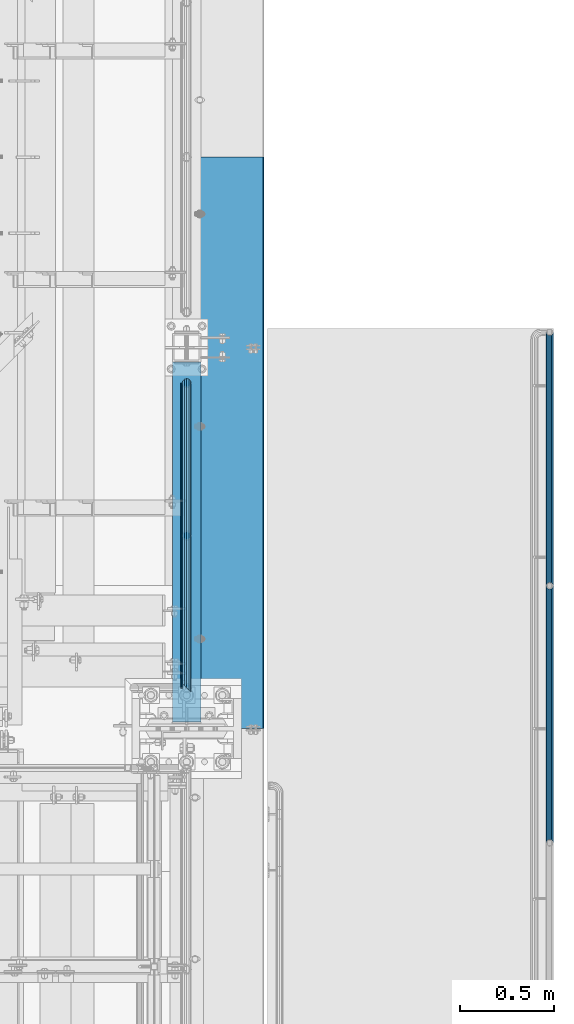
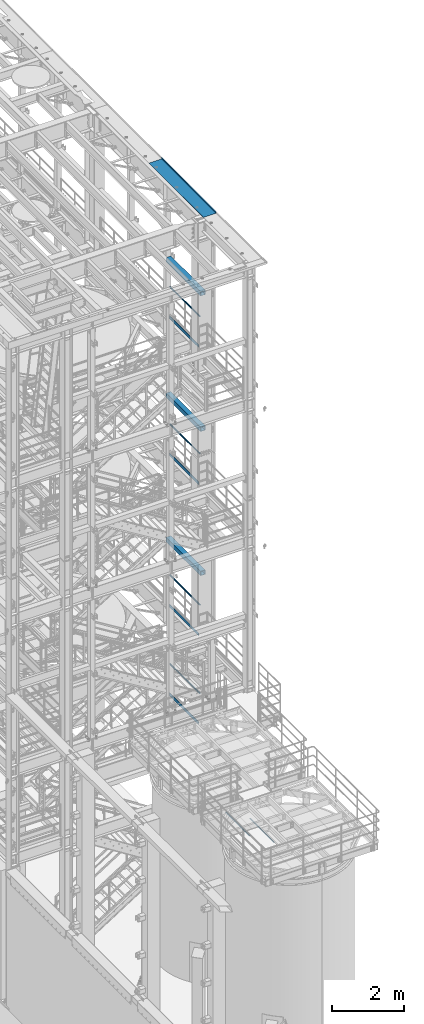
# One storey, part 1005 of 1876: 14 beams, 9 elements without a shape of their own.
"""IFC2X3 building model written with IfcOpenShell, lengths in millimetres."""

from ifc_helpers import new_model, si_unit, frame, origin_with_axes, place, context, subcontext, project, spatial, faceted_brep, material, type_object, element, aggregate, save


model = new_model("IFC2X3")

# Units and contexts
model_context = context("Model", 3, precision=1e-05, world=origin_with_axes())
body_context = subcontext(model_context, "Body", "Model", "MODEL_VIEW")
ifc_project = project(units=[si_unit("LENGTHUNIT", "METRE", prefix="MILLI"), si_unit("AREAUNIT", "SQUARE_METRE"), si_unit("VOLUMEUNIT", "CUBIC_METRE"), si_unit("MASSUNIT", "GRAM", prefix="KILO"), si_unit("TIMEUNIT", "SECOND"), si_unit("PLANEANGLEUNIT", "RADIAN"), si_unit("SOLIDANGLEUNIT", "STERADIAN"), si_unit("THERMODYNAMICTEMPERATUREUNIT", "DEGREE_CELSIUS"), si_unit("LUMINOUSINTENSITYUNIT", "LUMEN")], contexts=[model_context])

# Site, building, storey
site_placement = place(None, origin_with_axes())
site = spatial("IfcSite", under=ifc_project, at=site_placement, CompositionType="ELEMENT")
building_placement = place(site_placement, origin_with_axes())
building = spatial("IfcBuilding", under=site, at=building_placement, Name="Undefined", CompositionType="ELEMENT")
storey_placement = place(building_placement, origin_with_axes())
storey = spatial("IfcBuildingStorey", under=building, at=storey_placement, Name="Undefined", CompositionType="ELEMENT", Elevation=0.0)

# Assembly, beam
assembly_1_placement = place(storey_placement, origin_with_axes())
assembly_1 = element("IfcElementAssembly", 1, at=assembly_1_placement, inside=storey, Name="RAIL", AssemblyPlace="NOTDEFINED", PredefinedType="RIGID_FRAME")
ifc_material_1 = material()
beam_type_1 = type_object("IfcBeamType", Name="PIPE1-1/2SCH40", PredefinedType="NOTDEFINED")
beam_1_placement = place(assembly_1_placement, frame((7620.0, -4380.23, 19059.525), z_axis=(0.0, 0.0, -1.0), x_axis=(0.0, 1.0, 0.0)))
beam_1 = element("IfcBeam", 2, at=beam_1_placement, type_object=beam_type_1, material=ifc_material_1, Name="RAIL", ObjectType="PIPE1-1/2SCH40", context=body_context, shape_type="Brep", body=[
    faceted_brep([(44.5769999999984, -20.4470000000001, 0.0), (41.8376214311784, -17.7076214311801, 10.2235000000001), (1640.7003, -17.7076214311801, 10.2235000000001), (1650.9238, -20.4470000000001, 0.0), (34.3534999999983, -10.2235000000001, 17.7076214311819), (1633.21617856882, -10.2235000000001, 17.7076214311819), (24.1300000000064, 0.0, 20.4470000000001), (1630.4768, 0.0, 20.4470000000001), (13.9064999999982, 10.2235000000001, 17.7076214311819), (1633.21617856882, 10.2235000000001, 17.7076214311819), (6.4223785688182, 17.7076214311801, 10.2235000000001), (1640.7003, 17.7076214311801, 10.2235000000001), (3.68299999999817, 20.4470000000001, 0.0), (1650.9238, 20.4470000000001, 0.0), (6.4223785688182, 17.7076214311801, -10.2235000000001), (1661.1473, 17.7076214311801, -10.2235000000001), (13.9064999999982, 10.2235000000001, -17.7076214311819), (1668.63142143118, 10.2235000000001, -17.7076214311819), (24.1300000000063, 0.0, -20.4470000000001), (1671.3708, 0.0, -20.4470000000001), (34.3534999999983, -10.2235000000001, -17.7076214311819), (1668.63142143118, -10.2235000000001, -17.7076214311819), (41.8376214311784, -17.7076214311801, -10.2235000000001), (1661.1473, -17.7076214311801, -10.2235000000001), (48.2599999999984, -24.1300000000001, 0.0), (45.0271929933169, -20.8971929933186, -12.0649999999987), (1662.9888, -20.8971929933186, -12.0649999999987), (1650.9238, -24.1300000000001, 0.0), (36.1949999999979, -12.0649999999996, -20.8971929933177), (1671.82099299332, -12.0649999999996, -20.8971929933177), (24.1300000000063, 0.0, -24.130000000001), (1675.0538, 0.0, -24.130000000001), (12.0650000000041, 12.0650000000005, -20.8971929933177), (1671.82099299332, 12.0649999999996, -20.8971929933177), (3.23280700667965, 20.8971929933186, -12.0649999999987), (1662.9888, 20.8971929933186, -12.0649999999987), (0.0, 24.1299999999992, 0.0), (1650.9238, 24.1300000000001, 0.0), (3.23280700667965, 20.8971929933186, 12.0649999999987), (1638.8588, 20.8971929933186, 12.0649999999987), (12.0650000000041, 12.0650000000005, 20.8971929933177), (1630.02660700668, 12.0649999999996, 20.8971929933177), (24.1300000000064, 0.0, 24.130000000001), (1626.7938, 0.0, 24.130000000001), (36.1949999999979, -12.0649999999996, 20.8971929933177), (1630.02660700668, -12.0649999999996, 20.8971929933177), (45.0271929933169, -20.8971929933186, 12.0649999999987), (1638.8588, -20.8971929933186, 12.0649999999987)], [[[0, 1, 2, 3]], [[1, 4, 5, 2]], [[4, 6, 7, 5]], [[6, 8, 9, 7]], [[8, 10, 11, 9]], [[10, 12, 13, 11]], [[12, 14, 15, 13]], [[14, 16, 17, 15]], [[16, 18, 19, 17]], [[18, 20, 21, 19]], [[20, 22, 23, 21]], [[22, 0, 3, 23]], [[24, 25, 26, 27]], [[25, 28, 29, 26]], [[28, 30, 31, 29]], [[30, 32, 33, 31]], [[32, 34, 35, 33]], [[34, 36, 37, 35]], [[36, 38, 39, 37]], [[38, 40, 41, 39]], [[40, 42, 43, 41]], [[42, 44, 45, 43]], [[44, 46, 47, 45]], [[46, 24, 27, 47]], [[29, 31, 33, 35, 37, 39, 41, 43, 45, 47, 27, 26], [5, 7, 9, 11, 13, 15, 17, 19, 21, 23, 3, 2]], [[46, 44, 42, 40, 38, 36, 34, 32, 30, 28, 25, 24], [22, 20, 18, 16, 14, 12, 10, 8, 6, 4, 1, 0]]]),
])

assembly_2_placement = place(storey_placement, origin_with_axes())
assembly_2 = element("IfcElementAssembly", 3, at=assembly_2_placement, inside=storey, Name="RAIL", AssemblyPlace="NOTDEFINED", PredefinedType="RIGID_FRAME")
beam_2_placement = place(assembly_2_placement, frame((7620.0, -4380.23, 14385.925), z_axis=(0.0, 0.0, -1.0), x_axis=(0.0, 1.0, 0.0)))
beam_2 = element("IfcBeam", 4, at=beam_2_placement, type_object=beam_type_1, material=ifc_material_1, Name="RAIL", ObjectType="PIPE1-1/2SCH40", context=body_context, shape_type="Brep", body=[
    faceted_brep([(44.5769999999984, -20.4470000000001, 0.0), (41.8376214311784, -17.7076214311801, 10.2235000000001), (1640.7003, -17.7076214311801, 10.2235000000001), (1650.9238, -20.4470000000001, 0.0), (34.3534999999983, -10.2235000000001, 17.7076214311819), (1633.21617856882, -10.2235000000001, 17.7076214311819), (24.1300000000064, 0.0, 20.4470000000001), (1630.4768, 0.0, 20.4470000000001), (13.9064999999982, 10.2235000000001, 17.7076214311819), (1633.21617856882, 10.2235000000001, 17.7076214311819), (6.4223785688182, 17.7076214311801, 10.2235000000001), (1640.7003, 17.7076214311801, 10.2235000000001), (3.68299999999817, 20.4470000000001, 0.0), (1650.9238, 20.4470000000001, 0.0), (6.4223785688182, 17.7076214311801, -10.2235000000001), (1661.1473, 17.7076214311801, -10.2235000000001), (13.9064999999982, 10.2235000000001, -17.7076214311819), (1668.63142143118, 10.2235000000001, -17.7076214311819), (24.1300000000063, 0.0, -20.4470000000001), (1671.3708, 0.0, -20.4470000000001), (34.3534999999983, -10.2235000000001, -17.7076214311819), (1668.63142143118, -10.2235000000001, -17.7076214311819), (41.8376214311784, -17.7076214311801, -10.2235000000001), (1661.1473, -17.7076214311801, -10.2235000000001), (48.2599999999984, -24.1300000000001, 0.0), (45.0271929933169, -20.8971929933186, -12.0649999999987), (1662.9888, -20.8971929933186, -12.0649999999987), (1650.9238, -24.1300000000001, 0.0), (36.1949999999979, -12.0649999999996, -20.8971929933177), (1671.82099299332, -12.0649999999996, -20.8971929933177), (24.1300000000063, 0.0, -24.130000000001), (1675.0538, 0.0, -24.130000000001), (12.0650000000041, 12.0650000000005, -20.8971929933177), (1671.82099299332, 12.0649999999996, -20.8971929933177), (3.23280700667965, 20.8971929933186, -12.0649999999987), (1662.9888, 20.8971929933186, -12.0649999999987), (0.0, 24.1299999999992, 0.0), (1650.9238, 24.1300000000001, 0.0), (3.23280700667965, 20.8971929933186, 12.0649999999987), (1638.8588, 20.8971929933186, 12.0649999999987), (12.0650000000041, 12.0650000000005, 20.8971929933177), (1630.02660700668, 12.0649999999996, 20.8971929933177), (24.1300000000064, 0.0, 24.130000000001), (1626.7938, 0.0, 24.130000000001), (36.1949999999979, -12.0649999999996, 20.8971929933177), (1630.02660700668, -12.0649999999996, 20.8971929933177), (45.0271929933169, -20.8971929933186, 12.0649999999987), (1638.8588, -20.8971929933186, 12.0649999999987)], [[[0, 1, 2, 3]], [[1, 4, 5, 2]], [[4, 6, 7, 5]], [[6, 8, 9, 7]], [[8, 10, 11, 9]], [[10, 12, 13, 11]], [[12, 14, 15, 13]], [[14, 16, 17, 15]], [[16, 18, 19, 17]], [[18, 20, 21, 19]], [[20, 22, 23, 21]], [[22, 0, 3, 23]], [[24, 25, 26, 27]], [[25, 28, 29, 26]], [[28, 30, 31, 29]], [[30, 32, 33, 31]], [[32, 34, 35, 33]], [[34, 36, 37, 35]], [[36, 38, 39, 37]], [[38, 40, 41, 39]], [[40, 42, 43, 41]], [[42, 44, 45, 43]], [[44, 46, 47, 45]], [[46, 24, 27, 47]], [[29, 31, 33, 35, 37, 39, 41, 43, 45, 47, 27, 26], [5, 7, 9, 11, 13, 15, 17, 19, 21, 23, 3, 2]], [[46, 44, 42, 40, 38, 36, 34, 32, 30, 28, 25, 24], [22, 20, 18, 16, 14, 12, 10, 8, 6, 4, 1, 0]]]),
])

assembly_3_placement = place(storey_placement, origin_with_axes())
assembly_3 = element("IfcElementAssembly", 5, at=assembly_3_placement, inside=storey, Name="RAIL", AssemblyPlace="NOTDEFINED", PredefinedType="RIGID_FRAME")
beam_3_placement = place(assembly_3_placement, frame((7620.0, -4380.23, 9229.725), z_axis=(0.0, 0.0, -1.0), x_axis=(0.0, 1.0, 0.0)))
beam_3 = element("IfcBeam", 6, at=beam_3_placement, type_object=beam_type_1, material=ifc_material_1, Name="RAIL", ObjectType="PIPE1-1/2SCH40", context=body_context, shape_type="Brep", body=[
    faceted_brep([(44.5769999999984, -20.4470000000001, 0.0), (41.8376214311784, -17.7076214311801, 10.2235000000001), (1640.7003, -17.7076214311801, 10.2235000000001), (1650.9238, -20.4470000000001, 0.0), (34.3534999999983, -10.2235000000001, 17.7076214311819), (1633.21617856882, -10.2235000000001, 17.7076214311819), (24.1300000000064, 0.0, 20.4470000000001), (1630.4768, 0.0, 20.4470000000001), (13.9064999999982, 10.2235000000001, 17.7076214311819), (1633.21617856882, 10.2235000000001, 17.7076214311819), (6.4223785688182, 17.7076214311801, 10.2235000000001), (1640.7003, 17.7076214311801, 10.2235000000001), (3.68299999999817, 20.4470000000001, 0.0), (1650.9238, 20.4470000000001, 0.0), (6.4223785688182, 17.7076214311801, -10.2235000000001), (1661.1473, 17.7076214311801, -10.2235000000001), (13.9064999999982, 10.2235000000001, -17.7076214311819), (1668.63142143118, 10.2235000000001, -17.7076214311819), (24.1300000000063, 0.0, -20.4470000000001), (1671.3708, 0.0, -20.4470000000001), (34.3534999999983, -10.2235000000001, -17.7076214311819), (1668.63142143118, -10.2235000000001, -17.7076214311819), (41.8376214311784, -17.7076214311801, -10.2235000000001), (1661.1473, -17.7076214311801, -10.2235000000001), (48.2599999999984, -24.1300000000001, 0.0), (45.0271929933169, -20.8971929933186, -12.0649999999987), (1662.9888, -20.8971929933186, -12.0649999999987), (1650.9238, -24.1300000000001, 0.0), (36.1949999999979, -12.0649999999996, -20.8971929933177), (1671.82099299332, -12.0649999999996, -20.8971929933177), (24.1300000000063, 0.0, -24.130000000001), (1675.0538, 0.0, -24.130000000001), (12.0650000000041, 12.0650000000005, -20.8971929933177), (1671.82099299332, 12.0649999999996, -20.8971929933177), (3.23280700667965, 20.8971929933186, -12.0649999999987), (1662.9888, 20.8971929933186, -12.0649999999987), (0.0, 24.1299999999992, 0.0), (1650.9238, 24.1300000000001, 0.0), (3.23280700667965, 20.8971929933186, 12.0649999999987), (1638.8588, 20.8971929933186, 12.0649999999987), (12.0650000000041, 12.0650000000005, 20.8971929933177), (1630.02660700668, 12.0649999999996, 20.8971929933177), (24.1300000000064, 0.0, 24.130000000001), (1626.7938, 0.0, 24.130000000001), (36.1949999999979, -12.0649999999996, 20.8971929933177), (1630.02660700668, -12.0649999999996, 20.8971929933177), (45.0271929933169, -20.8971929933186, 12.0649999999987), (1638.8588, -20.8971929933186, 12.0649999999987)], [[[0, 1, 2, 3]], [[1, 4, 5, 2]], [[4, 6, 7, 5]], [[6, 8, 9, 7]], [[8, 10, 11, 9]], [[10, 12, 13, 11]], [[12, 14, 15, 13]], [[14, 16, 17, 15]], [[16, 18, 19, 17]], [[18, 20, 21, 19]], [[20, 22, 23, 21]], [[22, 0, 3, 23]], [[24, 25, 26, 27]], [[25, 28, 29, 26]], [[28, 30, 31, 29]], [[30, 32, 33, 31]], [[32, 34, 35, 33]], [[34, 36, 37, 35]], [[36, 38, 39, 37]], [[38, 40, 41, 39]], [[40, 42, 43, 41]], [[42, 44, 45, 43]], [[44, 46, 47, 45]], [[46, 24, 27, 47]], [[29, 31, 33, 35, 37, 39, 41, 43, 45, 47, 27, 26], [5, 7, 9, 11, 13, 15, 17, 19, 21, 23, 3, 2]], [[46, 44, 42, 40, 38, 36, 34, 32, 30, 28, 25, 24], [22, 20, 18, 16, 14, 12, 10, 8, 6, 4, 1, 0]]]),
])

assembly_4_placement = place(storey_placement, origin_with_axes())
assembly_4 = element("IfcElementAssembly", 7, at=assembly_4_placement, inside=storey, Name="RAIL", AssemblyPlace="NOTDEFINED", PredefinedType="RIGID_FRAME")
beam_4_placement = place(assembly_4_placement, frame((7620.0, -4380.23, 6207.125), z_axis=(0.0, 0.0, -1.0), x_axis=(0.0, 1.0, 0.0)))
beam_4 = element("IfcBeam", 8, at=beam_4_placement, type_object=beam_type_1, material=ifc_material_1, Name="RAIL", ObjectType="PIPE1-1/2SCH40", context=body_context, shape_type="Brep", body=[
    faceted_brep([(44.5769999999984, -20.4470000000001, 0.0), (41.8376214311784, -17.7076214311801, 10.2235000000001), (1640.7003, -17.7076214311801, 10.2235000000001), (1650.9238, -20.4470000000001, 0.0), (34.3534999999983, -10.2235000000001, 17.7076214311819), (1633.21617856882, -10.2235000000001, 17.7076214311819), (24.1300000000064, 0.0, 20.4470000000001), (1630.4768, 0.0, 20.4470000000001), (13.9064999999982, 10.2235000000001, 17.7076214311819), (1633.21617856882, 10.2235000000001, 17.7076214311819), (6.4223785688182, 17.7076214311801, 10.2235000000001), (1640.7003, 17.7076214311801, 10.2235000000001), (3.68299999999817, 20.4470000000001, 0.0), (1650.9238, 20.4470000000001, 0.0), (6.4223785688182, 17.7076214311801, -10.2235000000001), (1661.1473, 17.7076214311801, -10.2235000000001), (13.9064999999982, 10.2235000000001, -17.7076214311819), (1668.63142143118, 10.2235000000001, -17.7076214311819), (24.1300000000063, 0.0, -20.4470000000001), (1671.3708, 0.0, -20.4470000000001), (34.3534999999983, -10.2235000000001, -17.7076214311819), (1668.63142143118, -10.2235000000001, -17.7076214311819), (41.8376214311784, -17.7076214311801, -10.2235000000001), (1661.1473, -17.7076214311801, -10.2235000000001), (48.2599999999984, -24.1300000000001, 0.0), (45.0271929933169, -20.8971929933186, -12.0649999999987), (1662.9888, -20.8971929933186, -12.0649999999987), (1650.9238, -24.1300000000001, 0.0), (36.1949999999979, -12.0649999999996, -20.8971929933177), (1671.82099299332, -12.0649999999996, -20.8971929933177), (24.1300000000063, 0.0, -24.130000000001), (1675.0538, 0.0, -24.130000000001), (12.0650000000041, 12.0650000000005, -20.8971929933177), (1671.82099299332, 12.0649999999996, -20.8971929933177), (3.23280700667965, 20.8971929933186, -12.0649999999987), (1662.9888, 20.8971929933186, -12.0649999999987), (0.0, 24.1299999999992, 0.0), (1650.9238, 24.1300000000001, 0.0), (3.23280700667965, 20.8971929933186, 12.0649999999987), (1638.8588, 20.8971929933186, 12.0649999999987), (12.0650000000041, 12.0650000000005, 20.8971929933177), (1630.02660700668, 12.0649999999996, 20.8971929933177), (24.1300000000064, 0.0, 24.130000000001), (1626.7938, 0.0, 24.130000000001), (36.1949999999979, -12.0649999999996, 20.8971929933177), (1630.02660700668, -12.0649999999996, 20.8971929933177), (45.0271929933169, -20.8971929933186, 12.0649999999987), (1638.8588, -20.8971929933186, 12.0649999999987)], [[[0, 1, 2, 3]], [[1, 4, 5, 2]], [[4, 6, 7, 5]], [[6, 8, 9, 7]], [[8, 10, 11, 9]], [[10, 12, 13, 11]], [[12, 14, 15, 13]], [[14, 16, 17, 15]], [[16, 18, 19, 17]], [[18, 20, 21, 19]], [[20, 22, 23, 21]], [[22, 0, 3, 23]], [[24, 25, 26, 27]], [[25, 28, 29, 26]], [[28, 30, 31, 29]], [[30, 32, 33, 31]], [[32, 34, 35, 33]], [[34, 36, 37, 35]], [[36, 38, 39, 37]], [[38, 40, 41, 39]], [[40, 42, 43, 41]], [[42, 44, 45, 43]], [[44, 46, 47, 45]], [[46, 24, 27, 47]], [[29, 31, 33, 35, 37, 39, 41, 43, 45, 47, 27, 26], [5, 7, 9, 11, 13, 15, 17, 19, 21, 23, 3, 2]], [[46, 44, 42, 40, 38, 36, 34, 32, 30, 28, 25, 24], [22, 20, 18, 16, 14, 12, 10, 8, 6, 4, 1, 0]]]),
])

assembly_5_placement = place(storey_placement, origin_with_axes())
assembly_5 = element("IfcElementAssembly", 9, at=assembly_5_placement, inside=storey, Name="BEAM", AssemblyPlace="NOTDEFINED", PredefinedType="RIGID_FRAME")
ifc_material_2 = material()
beam_type_2 = type_object("IfcBeamType", Name="HSS6X6X3/8", PredefinedType="NOTDEFINED")
beam_5_placement = place(assembly_5_placement, frame((7620.0, -4560.09375, 19958.05), z_axis=(-1.0, 0.0, 0.0), x_axis=(0.0, 1.0, 0.0)))
beam_5 = element("IfcBeam", 10, at=beam_5_placement, type_object=beam_type_2, material=ifc_material_2, Name="BEAM", ObjectType="HSS6X6X3/8", context=body_context, shape_type="Brep", body=[
    faceted_brep([(22.2249999999995, 66.6749999999993, -66.675), (22.2249999999995, -66.6749999999993, -66.675), (1943.89375, -66.6749999999993, -66.675), (1943.89375, 66.6749999999993, -66.675), (22.2249999999995, -66.6749999999993, 66.675), (1943.89375, -66.6749999999993, 66.675), (22.2249999999995, 66.6749999999993, 66.675), (1943.89375, 66.6749999999993, 66.675), (22.2249999999995, 76.2000000000007, -76.2), (22.2249999999995, 76.2000000000007, 76.2), (1943.89375, 76.2000000000007, 76.2), (1943.89375, 76.2000000000007, -76.2), (22.2249999999995, -76.2000000000007, 76.2), (1943.89375, -76.2000000000007, 76.2), (22.2249999999995, -76.2000000000007, -76.2), (1943.89375, -76.2000000000007, -76.2)], [[[0, 1, 2, 3]], [[1, 4, 5, 2]], [[4, 6, 7, 5]], [[6, 0, 3, 7]], [[8, 9, 10, 11]], [[9, 12, 13, 10]], [[12, 14, 15, 13]], [[14, 8, 11, 15]], [[13, 15, 11, 10], [5, 7, 3, 2]], [[14, 12, 9, 8], [6, 4, 1, 0]]]),
])
aggregate(assembly_5, [beam_5])

assembly_6_placement = place(storey_placement, origin_with_axes())
assembly_6 = element("IfcElementAssembly", 11, at=assembly_6_placement, inside=storey, Name="BEAM", AssemblyPlace="NOTDEFINED", PredefinedType="RIGID_FRAME")
beam_6_placement = place(assembly_6_placement, frame((7620.0, -4560.09375, 15335.25), z_axis=(-1.0, 0.0, 0.0), x_axis=(0.0, 1.0, 0.0)))
beam_6 = element("IfcBeam", 12, at=beam_6_placement, type_object=beam_type_2, material=ifc_material_2, Name="BEAM", ObjectType="HSS6X6X3/8", context=body_context, shape_type="Brep", body=[
    faceted_brep([(22.2249999999995, 66.6749999999993, -66.675), (22.2249999999995, -66.6749999999993, -66.675), (1943.89375, -66.6749999999993, -66.675), (1943.89375, 66.6749999999993, -66.675), (22.2249999999995, -66.6749999999993, 66.675), (1943.89375, -66.6749999999993, 66.675), (22.2249999999995, 66.6749999999993, 66.675), (1943.89375, 66.6749999999993, 66.675), (22.2249999999995, 76.2000000000007, -76.2), (22.2249999999995, 76.2000000000007, 76.2), (1943.89375, 76.2000000000007, 76.2), (1943.89375, 76.2000000000007, -76.2), (22.2249999999995, -76.2000000000007, 76.2), (1943.89375, -76.2000000000007, 76.2), (22.2249999999995, -76.2000000000007, -76.2), (1943.89375, -76.2000000000007, -76.2)], [[[0, 1, 2, 3]], [[1, 4, 5, 2]], [[4, 6, 7, 5]], [[6, 0, 3, 7]], [[8, 9, 10, 11]], [[9, 12, 13, 10]], [[12, 14, 15, 13]], [[14, 8, 11, 15]], [[13, 15, 11, 10], [5, 7, 3, 2]], [[14, 12, 9, 8], [6, 4, 1, 0]]]),
])
aggregate(assembly_6, [beam_6])

assembly_7_placement = place(storey_placement, origin_with_axes())
assembly_7 = element("IfcElementAssembly", 13, at=assembly_7_placement, inside=storey, Name="BEAM", AssemblyPlace="NOTDEFINED", PredefinedType="RIGID_FRAME")
beam_7_placement = place(assembly_7_placement, frame((7620.0, -4560.09375, 10420.35), z_axis=(-1.0, 0.0, 0.0), x_axis=(0.0, 1.0, 0.0)))
beam_7 = element("IfcBeam", 14, at=beam_7_placement, type_object=beam_type_2, material=ifc_material_2, Name="BEAM", ObjectType="HSS6X6X3/8", context=body_context, shape_type="Brep", body=[
    faceted_brep([(22.2249999999995, 66.6749999999993, -66.675), (22.2249999999995, -66.6749999999993, -66.675), (1943.89375, -66.6749999999993, -66.675), (1943.89375, 66.6749999999993, -66.675), (22.2249999999995, -66.6749999999993, 66.675), (1943.89375, -66.6749999999993, 66.675), (22.2249999999995, 66.6749999999993, 66.675), (1943.89375, 66.6749999999993, 66.675), (22.2249999999995, 76.2000000000007, -76.2), (22.2249999999995, 76.2000000000007, 76.2), (1943.89375, 76.2000000000007, 76.2), (1943.89375, 76.2000000000007, -76.2), (22.2249999999995, -76.2000000000007, 76.2), (1943.89375, -76.2000000000007, 76.2), (22.2249999999995, -76.2000000000007, -76.2), (1943.89375, -76.2000000000007, -76.2)], [[[0, 1, 2, 3]], [[1, 4, 5, 2]], [[4, 6, 7, 5]], [[6, 0, 3, 7]], [[8, 9, 10, 11]], [[9, 12, 13, 10]], [[12, 14, 15, 13]], [[14, 8, 11, 15]], [[13, 15, 11, 10], [5, 7, 3, 2]], [[14, 12, 9, 8], [6, 4, 1, 0]]]),
])
aggregate(assembly_7, [beam_7])

# Beam
ifc_material_3 = material(Name="STEEL/A36")
beam_type_3 = type_object("IfcBeamType", PredefinedType="NOTDEFINED")
beam_8_placement = place(assembly_1_placement, frame((7592.69500000001, -4356.10000000001, 18049.875), z_axis=(0.0, 0.0, 1.0), x_axis=(0.0, 1.0, 0.0)))
beam_8 = element("IfcBeam", 15, at=beam_8_placement, type_object=beam_type_3, material=ifc_material_3, Name="PLATE", context=body_context, shape_type="Brep", body=[
    faceted_brep([(0.0, 3.17500000000018, -50.8000000000002), (0.0, 3.17500000000018, 50.8000000000002), (1626.7938, 3.175, 50.7999999999993), (1626.7938, 3.175, -50.7999999999993), (0.0, -3.17500000000018, 50.8000000000002), (1626.7938, -3.175, 50.7999999999993), (0.0, -3.17500000000018, -50.8000000000002), (1626.7938, -3.175, -50.7999999999993)], [[[0, 1, 2, 3]], [[1, 4, 5, 2]], [[4, 6, 7, 5]], [[6, 0, 3, 7]], [[5, 7, 3, 2]], [[6, 4, 1, 0]]]),
])

aggregate(assembly_1, [beam_8, beam_1])

beam_9_placement = place(assembly_2_placement, frame((7592.69500000001, -4356.10000000001, 13376.275), z_axis=(0.0, 0.0, 1.0), x_axis=(0.0, 1.0, 0.0)))
beam_9 = element("IfcBeam", 16, at=beam_9_placement, type_object=beam_type_3, material=ifc_material_3, Name="PLATE", context=body_context, shape_type="Brep", body=[
    faceted_brep([(0.0, 3.17500000000018, -50.8000000000002), (0.0, 3.17500000000018, 50.8000000000002), (1626.7938, 3.175, 50.7999999999993), (1626.7938, 3.175, -50.7999999999993), (0.0, -3.17500000000018, 50.8000000000002), (1626.7938, -3.175, 50.7999999999993), (0.0, -3.17500000000018, -50.8000000000002), (1626.7938, -3.175, -50.7999999999993)], [[[0, 1, 2, 3]], [[1, 4, 5, 2]], [[4, 6, 7, 5]], [[6, 0, 3, 7]], [[5, 7, 3, 2]], [[6, 4, 1, 0]]]),
])

aggregate(assembly_2, [beam_9, beam_2])

beam_10_placement = place(assembly_3_placement, frame((7592.69500000001, -4356.1, 8220.075), z_axis=(0.0, 0.0, 1.0), x_axis=(0.0, 1.0, 0.0)))
beam_10 = element("IfcBeam", 17, at=beam_10_placement, type_object=beam_type_3, material=ifc_material_3, Name="PLATE", context=body_context, shape_type="Brep", body=[
    faceted_brep([(0.0, 3.17500000000018, -50.8000000000002), (0.0, 3.17500000000018, 50.8000000000002), (1626.7938, 3.175, 50.7999999999993), (1626.7938, 3.175, -50.7999999999993), (0.0, -3.17500000000018, 50.8000000000002), (1626.7938, -3.175, 50.7999999999993), (0.0, -3.17500000000018, -50.8000000000002), (1626.7938, -3.175, -50.7999999999993)], [[[0, 1, 2, 3]], [[1, 4, 5, 2]], [[4, 6, 7, 5]], [[6, 0, 3, 7]], [[5, 7, 3, 2]], [[6, 4, 1, 0]]]),
])

aggregate(assembly_3, [beam_10, beam_3])

beam_11_placement = place(assembly_4_placement, frame((7592.69500000001, -4356.10000000001, 5197.475), z_axis=(0.0, 0.0, 1.0), x_axis=(0.0, 1.0, 0.0)))
beam_11 = element("IfcBeam", 18, at=beam_11_placement, type_object=beam_type_3, material=ifc_material_3, Name="PLATE", context=body_context, shape_type="Brep", body=[
    faceted_brep([(0.0, 3.17500000000018, -50.8000000000002), (0.0, 3.17500000000018, 50.8000000000002), (1626.7938, 3.175, 50.7999999999993), (1626.7938, 3.175, -50.7999999999993), (0.0, -3.17500000000018, 50.8000000000002), (1626.7938, -3.175, 50.7999999999993), (0.0, -3.17500000000018, -50.8000000000002), (1626.7938, -3.175, -50.7999999999993)], [[[0, 1, 2, 3]], [[1, 4, 5, 2]], [[4, 6, 7, 5]], [[6, 0, 3, 7]], [[5, 7, 3, 2]], [[6, 4, 1, 0]]]),
])

aggregate(assembly_4, [beam_11, beam_4])

# Assembly, beam
assembly_8_placement = place(storey_placement, origin_with_axes())
assembly_8 = element("IfcElementAssembly", 19, at=assembly_8_placement, inside=storey, Name="BENT PLATE", AssemblyPlace="NOTDEFINED", PredefinedType="RIGID_FRAME")
beam_type_4 = type_object("IfcBeamType", PredefinedType="NOTDEFINED")
beam_12_placement = place(assembly_8_placement, frame((7619.99998321378, -3048.0, 22558.375), z_axis=(0.0, 1.0, 0.0), x_axis=(0.999999999986024, 0.0, -5.28699999861059e-06)))
beam_12 = element("IfcBeam", 20, at=beam_12_placement, type_object=beam_type_4, material=ifc_material_3, Name="BENT PLATE", context=body_context, shape_type="Brep", body=[
    faceted_brep([(9.877112461254e-10, -3.17499999999563, -1524.0), (9.877112461254e-10, -3.17499999999563, 1524.0), (-9.88620740827173e-10, 3.17500000000291, 1524.0), (-9.88620740827173e-10, 3.17500000000291, -1524.0), (412.74996162189, 3.17499999736538, 1524.0), (412.74996162189, 3.17499999736538, -1524.0), (406.399963385245, -3.17500000258951, -1524.0), (406.399963385245, -3.17500000258951, 1524.0), (412.749980137296, -63.5005721684938, 1524.0), (412.749980137296, -63.5005721684938, -1524.0), (406.399980137296, -63.5005739318367, 1524.0), (406.399980137296, -63.5005739318367, -1524.0)], [[[0, 1, 2, 3]], [[3, 2, 4, 5]], [[1, 0, 6, 7]], [[5, 4, 8, 9]], [[4, 2, 1, 7, 10, 8]], [[7, 6, 11, 10]], [[6, 0, 3, 5, 9, 11]], [[10, 11, 9, 8]]]),
])
aggregate(assembly_8, [beam_12])

# Assembly, beams
assembly_9_placement = place(storey_placement, origin_with_axes())
assembly_9 = element("IfcElementAssembly", 21, at=assembly_9_placement, inside=storey, Name="RAIL", AssemblyPlace="NOTDEFINED", PredefinedType="RIGID_FRAME")
beam_type_5 = type_object("IfcBeamType", PredefinedType="NOTDEFINED")
beam_13_placement = place(assembly_9_placement, frame((9556.7501953125, -3810.00009765737, 330.200003052719), z_axis=(0.0, 0.0, 1.0), x_axis=(0.0, 1.0, 0.0)))
beam_13 = element("IfcBeam", 22, at=beam_13_placement, type_object=beam_type_5, material=ifc_material_2, Name="RAIL", context=body_context, shape_type="Brep", body=[
    faceted_brep([(1336.05231371391, -9.52499999999964, 16.4977839420936), (1336.05231371391, -9.52499999999964, 12.160653285078), (1335.62694437092, -7.9375, 13.748153285078), (1333.500097656, 0.0, 15.875), (1333.500097656, 0.0, 19.05), (1335.62694437092, 7.9375, 13.7481532850779), (1336.05231371391, 9.52499999999964, 12.160653285078), (1336.05231371391, 9.52499999999964, 16.4977839420936), (1352.55009765727, 19.0499999999993, 0.0), (1343.025097656, 16.4977839420935, 9.52500000000003), (1343.025097656, 16.4977839420935, -9.52499999999998), (1340.27546699899, 13.7481532850779, 7.9375), (1342.40231371391, 15.875, 0.0), (1340.27546699899, 13.7481532850779, -7.9375), (1336.05231371391, 9.52499999999964, -12.160653285078), (1336.05231371391, 9.52499999999964, -16.4977839420936), (1335.62694437092, 7.9375, -13.748153285078), (1333.500097656, 0.0, -15.875), (1333.500097656, 0.0, -19.05), (1336.05231371391, -9.52499999999964, -12.160653285078), (1336.05231371391, -9.52499999999964, -16.4977839420936), (1335.62694437092, -7.9375, -13.748153285078), (1352.550097656, -19.0499999999993, 0.0), (1343.025097656, -16.4977839420935, -9.52500000000003), (1343.025097656, -16.4977839420935, 9.52499999999998), (1340.27546699899, -13.7481532850779, -7.9375), (1342.40231371391, -15.875, 0.0), (1340.27546699899, -13.7481532850779, 7.9375), (9.52499999999964, -16.4977839420935, -9.52499999999986), (16.4977839420935, -9.52499999999964, -16.4977839420934), (-9.09494701772928e-13, 19.05, -1.81898940354586e-12), (9.52499999999964, 16.4977839420935, -9.52499999999986), (9.52499999999964, 16.4977839420935, 9.52500000000009), (16.4977839420935, 9.52500000000055, 16.4977839420937), (19.0499999999993, 1.83105457836064e-05, 19.0500000000002), (16.4977839420935, 9.52500000000055, -16.4977839420934), (19.0499999999993, 0.0, -19.0499999999998), (19.0499999987278, 0.0, -15.875), (16.4977839408211, -9.52499999999964, -12.160653285078), (16.9231532838057, -7.9375, -13.748153285078), (16.9231532838057, 7.9375, -13.748153285078), (16.4977839408211, 9.52499999999964, -12.160653285078), (12.2746306557433, 13.7481532850779, -7.9375), (10.1477839408212, 15.875, 0.0), (12.2746306557433, 13.7481532850779, 7.9375), (16.4977839408211, 9.52499999999964, 12.160653285078), (16.9231532838057, 7.9375, 13.7481532850779), (19.0499999987278, 0.0, 15.875), (16.9231532838057, -7.9375, 13.748153285078), (16.4977839408211, -9.52499999999964, 12.160653285078), (16.4977839420935, -9.52499999999964, 16.4977839420937), (9.52499999999964, -16.4977839420935, 9.52500000000009), (0.0, -19.0500000000002, 0.0), (12.2746306557433, -13.7481532850779, 7.9375), (10.1477839408212, -15.875, 0.0), (12.2746306557433, -13.7481532850779, -7.9375)], [[[0, 1, 2, 3, 4]], [[4, 3, 5, 6, 7]], [[8, 9, 10]], [[7, 6, 11, 12, 13, 14, 15, 10, 9]], [[16, 17, 18, 15, 14]], [[19, 20, 18, 17, 21]], [[22, 23, 24]], [[24, 23, 20, 19, 25, 26, 27, 1, 0]], [[28, 29, 20, 23]], [[30, 31, 32]], [[33, 34, 4, 7]], [[32, 33, 7, 9]], [[30, 32, 9, 8]], [[31, 30, 8, 10]], [[35, 31, 10, 15]], [[36, 35, 15, 18]], [[29, 36, 18, 20]], [[37, 36, 29, 38, 39]], [[40, 41, 35, 36, 37]], [[32, 31, 35, 41, 42, 43, 44, 45, 33]], [[33, 45, 46, 47, 34]], [[34, 47, 48, 49, 50]], [[34, 50, 0, 4]], [[50, 51, 24, 0]], [[51, 52, 22, 24]], [[52, 28, 23, 22]], [[51, 28, 52]], [[50, 49, 53, 54, 55, 38, 29, 28, 51]], [[55, 54, 26, 25]], [[21, 39, 38, 55, 25, 19]], [[37, 39, 21, 17]], [[40, 37, 17, 16]], [[42, 41, 40, 16, 14, 13]], [[43, 42, 13, 12]], [[44, 43, 12, 11]], [[5, 46, 45, 44, 11, 6]], [[47, 46, 5, 3]], [[48, 47, 3, 2]], [[53, 49, 48, 2, 1, 27]], [[54, 53, 27, 26]]]),
])
beam_14_placement = place(assembly_9_placement, frame((9556.7501953125, -3810.00009765737, 939.800003052719), z_axis=(0.0, 0.0, -1.0), x_axis=(0.0, -1.0, 0.0)))
beam_14 = element("IfcBeam", 23, at=beam_14_placement, type_object=beam_type_5, material=ifc_material_1, Name="RAIL", context=body_context, shape_type="Brep", body=[
    faceted_brep([(-9.09494701772928e-13, 19.05, -1.81898940354586e-12), (9.52499999999964, 16.4977839420935, -9.52499999999986), (9.52499999999964, 16.4977839420935, 9.52500000000009), (9.52499999999964, -16.4977839420935, 9.52500000000009), (9.52499999999964, -16.4977839420935, -9.52499999999986), (0.0, -19.0500000000002, 0.0), (16.4977839420935, -9.52499999999964, 16.4977839420937), (16.4977839408211, -9.52499999999964, 12.160653285078), (12.2746306557433, -13.7481532850779, 7.9375), (10.1477839408212, -15.875, 0.0), (12.2746306557433, -13.7481532850779, -7.9375), (16.4977839408211, -9.52499999999964, -12.160653285078), (16.4977839420935, -9.52499999999964, -16.4977839420934), (19.0499999987278, 0.0, -15.875), (19.0499999999993, 0.0, -19.0499999999998), (16.9231532838057, -7.9375, -13.748153285078), (16.9231532838057, 7.9375, -13.748153285078), (16.4977839408211, 9.52499999999964, -12.160653285078), (16.4977839420935, 9.52500000000055, -16.4977839420934), (12.2746306557433, 13.7481532850779, -7.9375), (10.1477839408212, 15.875, 0.0), (12.2746306557433, 13.7481532850779, 7.9375), (16.4977839408211, 9.52499999999964, 12.160653285078), (16.4977839420935, 9.52500000000055, 16.4977839420937), (16.9231532838057, 7.9375, 13.7481532850779), (19.0499999987278, 0.0, 15.875), (19.0499999999993, 1.83105457836064e-05, 19.0500000000002), (16.9231532838057, -7.9375, 13.748153285078), (1371.6, 19.0499999999993, 0.0), (1362.07499999873, 16.4977839420935, -9.52499999999998), (1355.10221605663, 9.52499999999964, -16.4977839420936), (1371.59999999873, -19.0499999999993, 0.0), (1362.07499999873, -16.4977839420935, -9.52500000000003), (1362.07499999873, -16.4977839420935, 9.52499999999998), (1355.10221605663, -9.52499999999964, 16.4977839420936), (1355.10221605663, -9.52499999999964, -16.4977839420936), (1352.54999999873, 0.0, -19.05), (1354.67684671365, 7.9375, -13.748153285078), (1352.54999999873, 0.0, -15.875), (1355.10221605663, 9.52499999999964, -12.160653285078), (1355.10221605663, -9.52499999999964, -12.160653285078), (1354.67684671365, -7.9375, -13.748153285078), (1359.32536934171, -13.7481532850779, -7.9375), (1361.45221605663, -15.875, 0.0), (1359.32536934171, -13.7481532850779, 7.9375), (1355.10221605663, -9.52499999999964, 12.160653285078), (1354.67684671365, -7.9375, 13.748153285078), (1352.54999999873, 0.0, 15.875), (1352.54999999873, 0.0, 19.05), (1355.10221605663, 9.52499999999964, 16.4977839420936), (1362.07499999873, 16.4977839420935, 9.52500000000003), (1355.10221605663, 9.52499999999964, 12.160653285078), (1359.32536934171, 13.7481532850779, 7.9375), (1361.45221605663, 15.875, 0.0), (1359.32536934171, 13.7481532850779, -7.9375), (1354.67684671365, 7.9375, 13.7481532850779)], [[[0, 1, 2]], [[3, 4, 5]], [[6, 7, 8, 9, 10, 11, 12, 4, 3]], [[13, 14, 12, 11, 15]], [[16, 17, 18, 14, 13]], [[2, 1, 18, 17, 19, 20, 21, 22, 23]], [[23, 22, 24, 25, 26]], [[26, 25, 27, 7, 6]], [[1, 0, 28, 29]], [[18, 1, 29, 30]], [[31, 32, 33]], [[6, 3, 33, 34]], [[3, 5, 31, 33]], [[5, 4, 32, 31]], [[4, 12, 35, 32]], [[12, 14, 36, 35]], [[14, 18, 30, 36]], [[37, 38, 36, 30, 39]], [[40, 35, 36, 38, 41]], [[33, 32, 35, 40, 42, 43, 44, 45, 34]], [[34, 45, 46, 47, 48]], [[26, 6, 34, 48]], [[2, 23, 49, 50]], [[23, 26, 48, 49]], [[0, 2, 50, 28]], [[28, 50, 29]], [[49, 51, 52, 53, 54, 39, 30, 29, 50]], [[48, 47, 55, 51, 49]], [[25, 24, 55, 47]], [[55, 24, 22, 21, 52, 51]], [[21, 20, 53, 52]], [[20, 19, 54, 53]], [[19, 17, 16, 37, 39, 54]], [[16, 13, 38, 37]], [[13, 15, 41, 38]], [[41, 15, 11, 10, 42, 40]], [[10, 9, 43, 42]], [[9, 8, 44, 43]], [[8, 7, 27, 46, 45, 44]], [[27, 25, 47, 46]]]),
])
aggregate(assembly_9, [beam_13, beam_14])

save(model, "model.ifc")
